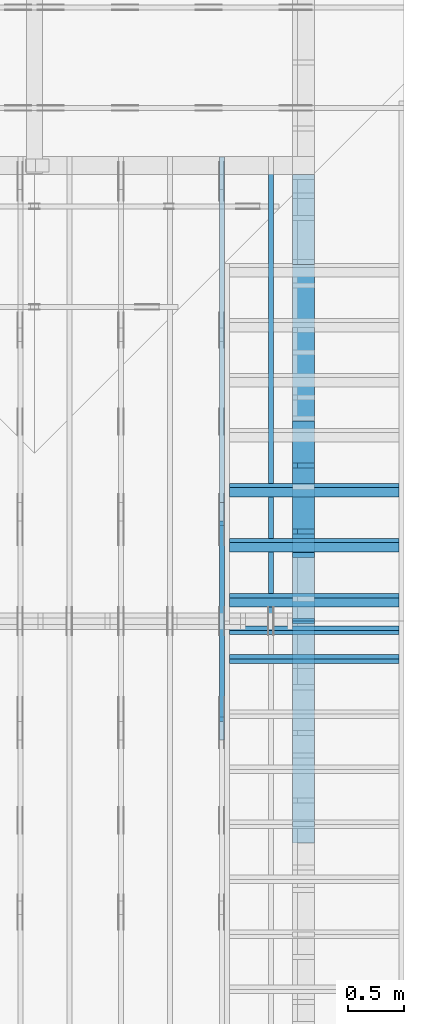
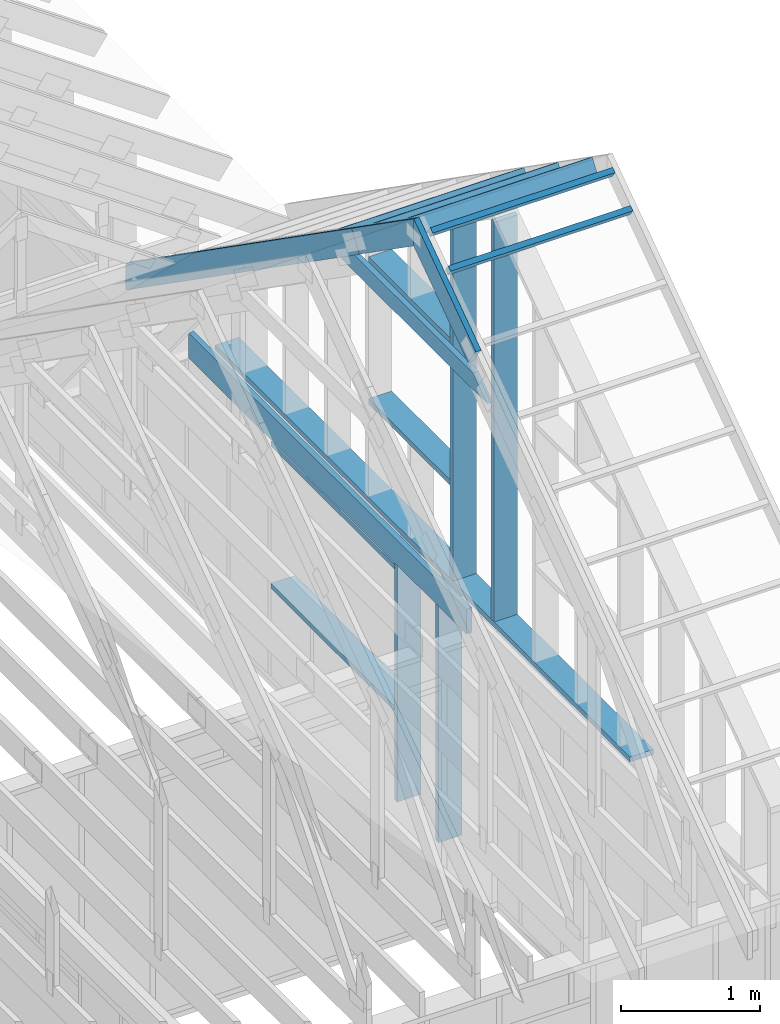
# One storey, part 27 of 70: 19 members, 6 elements without a shape of their own.
"""IFC2X3 building model written with IfcOpenShell, lengths in millimetres."""

import ifcopenshell
import ifcopenshell.guid

model = None  # the IFC model being written
_history = None  # IfcOwnerHistory: only IFC2X3 demands one
_inside = {}  # id of a spatial element -> (the spatial element, [elements in it])
_under = {}  # id of a project, library or spatial element -> (it, [spatial elements below it])
_declared = {}  # id of a project -> (the project, [libraries it declares])
_typed = {}  # id of a type object -> (the type object, [elements of that type])
_made_of = {}  # id of a material, layer set ... -> (it, [elements and type objects made of it])


def new_model(schema):
    """Start an empty IFC model of exactly this schema.

    Asked for "IFC4X3", IfcOpenShell would pick the latest addendum, in which some entities
    have other attributes; the version numbers below select the first issue.
    IFC2X3 requires an IfcOwnerHistory on every rooted entity: one is made here for all.
    """
    global model, _history
    if schema == "IFC4X3":
        model = ifcopenshell.file(schema_version=(4, 3, 0, 0))
    else:
        model = ifcopenshell.file(schema=schema)
    _inside.clear()
    _under.clear()
    _declared.clear()
    _typed.clear()
    _made_of.clear()
    _history = None
    if model.schema == "IFC2X3":
        org = make("IfcOrganization", Name="unknown")
        user = make(
            "IfcPersonAndOrganization",
            ThePerson=make("IfcPerson", FamilyName="unknown"),
            TheOrganization=org,
        )
        app = make(
            "IfcApplication",
            ApplicationDeveloper=org,
            Version="unknown",
            ApplicationFullName="unknown",
            ApplicationIdentifier="unknown",
        )
        _history = make(
            "IfcOwnerHistory",
            OwningUser=user,
            OwningApplication=app,
            ChangeAction="ADDED",
            CreationDate=0,
        )
    return model


def make(cls, **values):
    """One entity of the class cls with the attributes given. An attribute that is None is left unset."""
    return model.create_entity(
        cls, **{name: value for name, value in values.items() if value is not None}
    )


def rooted(cls, **values):
    """An entity with a GlobalId (a new one), such as an element, a storey or a relation."""
    return make(cls, GlobalId=ifcopenshell.guid.new(), OwnerHistory=_history, **values)


def si_unit(unit_type, name, prefix=None):
    """IfcSIUnit, for example si_unit("LENGTHUNIT", "METRE", prefix="MILLI")."""
    return make("IfcSIUnit", UnitType=unit_type, Prefix=prefix, Name=name)


def assignment(units):
    """IfcUnitAssignment: the units of a project."""
    return None if units is None else make("IfcUnitAssignment", Units=units)


def point(xyz):
    """IfcCartesianPoint."""
    return None if xyz is None else make("IfcCartesianPoint", Coordinates=xyz)


def direction(xyz):
    """IfcDirection."""
    return None if xyz is None else make("IfcDirection", DirectionRatios=xyz)


def frame(location, z_axis=None, x_axis=None):
    """IfcAxis2Placement3D, a coordinate frame: its origin and axes. An axis left out is left unset."""
    return make(
        "IfcAxis2Placement3D",
        Location=point(location),
        Axis=direction(z_axis),
        RefDirection=direction(x_axis),
    )


def frame_2d(location, x_axis=None):
    """IfcAxis2Placement2D, a coordinate frame in the plane: its origin and x axis."""
    return make(
        "IfcAxis2Placement2D", Location=point(location), RefDirection=direction(x_axis)
    )


def origin():
    """The frame at (0, 0, 0) with its axes left unset."""
    return frame((0.0, 0.0, 0.0))


def origin_with_axes():
    """The frame at (0, 0, 0) with the z axis (0, 0, 1) and the x axis (1, 0, 0) written out."""
    return frame((0.0, 0.0, 0.0), z_axis=(0.0, 0.0, 1.0), x_axis=(1.0, 0.0, 0.0))


def origin_2d():
    """The frame at (0, 0) in the plane with its x axis left unset."""
    return frame_2d((0.0, 0.0))


def place(relative_to, where):
    """IfcLocalPlacement: puts the frame where relative to a parent placement (None: the world)."""
    return make(
        "IfcLocalPlacement", PlacementRelTo=relative_to, RelativePlacement=where
    )


def context(
    kind, dimensions, precision=None, world=None, true_north=None, identifier=None
):
    """IfcGeometricRepresentationContext, for example the 3D "Model" context."""
    return make(
        "IfcGeometricRepresentationContext",
        ContextIdentifier=identifier,
        ContextType=kind,
        CoordinateSpaceDimension=dimensions,
        Precision=precision,
        WorldCoordinateSystem=world,
        TrueNorth=true_north,
    )


def project(units=None, contexts=None):
    """IfcProject with its units and contexts."""
    return rooted(
        "IfcProject",
        Name="project",
        RepresentationContexts=contexts,
        UnitsInContext=assignment(units),
    )


def spatial(cls, under=None, at=None, **own):
    """A site, building, storey or space (cls), placed at a placement, below another one or the project."""
    s = rooted(cls, ObjectPlacement=at, **own)
    if under is not None:
        _under.setdefault(under.id(), (under, []))[1].append(s)
    return s


def faces_of(points, faces, orient=None, outer=None):
    """IfcFace entities. A face is a list of loops; a loop is a list of indices into points, from 0.

    orient and outer hold one flag for each loop. By default every Orientation is true, the
    first loop of a face is its IfcFaceOuterBound and the others are IfcFaceBound.
    """
    made = []
    for i, loops in enumerate(faces):
        bounds = []
        for j, loop in enumerate(loops):
            is_outer = j == 0 if outer is None else outer[i][j]
            bounds.append(
                make(
                    "IfcFaceOuterBound" if is_outer else "IfcFaceBound",
                    Bound=make("IfcPolyLoop", Polygon=[points[k] for k in loop]),
                    Orientation=True if orient is None else orient[i][j],
                )
            )
        made.append(make("IfcFace", Bounds=bounds))
    return made


def faceted_brep(points, faces, orient=None, outer=None, voids=None):
    """IfcFacetedBrep: a solid bounded by flat faces; with voids (closed shells), ...WithVoids."""
    shared = [point(p) for p in points]
    hull = make("IfcClosedShell", CfsFaces=faces_of(shared, faces, orient, outer))
    if voids is None:
        return make("IfcFacetedBrep", Outer=hull)
    return make(
        "IfcFacetedBrepWithVoids",
        Outer=hull,
        Voids=[
            make(cls, CfsFaces=faces_of(shared, fs, o, b)) for cls, fs, o, b in voids
        ],
    )


def shape(context_of_items, identifier, shape_type, items):
    """IfcShapeRepresentation: the items that make up one representation, for example the "Body"."""
    return make(
        "IfcShapeRepresentation",
        ContextOfItems=context_of_items,
        RepresentationIdentifier=identifier,
        RepresentationType=shape_type,
        Items=items,
    )


def made_of(thing, what):
    """Note that an element or type object is made of a material, layer set ...; save() writes the relation."""
    if what is not None:
        _made_of.setdefault(what.id(), (what, []))[1].append(thing)
    return thing


def element(
    cls,
    number,
    at=None,
    inside=None,
    cuts=None,
    type_object=None,
    material=None,
    context=None,
    identifier="Body",
    shape_type=None,
    held_by="IfcProductDefinitionShape",
    body=None,
    shapes=None,
    **own,
):
    """One element of the class cls, such as IfcWall. Its Tag is "e" and its number.

    at: its placement. inside: the storey or other place that contains it. cuts: it is an
    opening in that element (IfcRelVoidsElement). A single representation is given by context,
    identifier, shape_type and body (its items); several are given by shapes. held_by: the class
    of the entity that holds the representations. save() writes the other relations.
    """
    e = rooted(cls, Tag="e%d" % number, ObjectPlacement=at, **own)
    if body is not None:
        shapes = [shape(context, identifier, shape_type, body)]
    if shapes is not None:
        e.Representation = make(held_by, Representations=shapes)
    if inside is not None:
        _inside.setdefault(inside.id(), (inside, []))[1].append(e)
    if cuts is not None:
        rooted(
            "IfcRelVoidsElement", RelatingBuildingElement=cuts, RelatedOpeningElement=e
        )
    if type_object is not None:
        _typed.setdefault(type_object.id(), (type_object, []))[1].append(e)
    return made_of(e, material)


def aggregate(whole, parts):
    """IfcRelAggregates: a whole, such as a stair, and the parts it consists of."""
    return rooted("IfcRelAggregates", RelatingObject=whole, RelatedObjects=parts)


def save(model, path):
    """Write the relations noted so far, then the file.

    IfcRelAggregates (storeys below a building ...), IfcRelContainedInSpatialStructure (elements
    in a storey), IfcRelDefinesByType, IfcRelAssociatesMaterial and IfcRelDeclares: one each for
    every whole, place, type object, material and project.
    """
    for whole, parts in _under.values():
        aggregate(whole, parts)
    for where, things in _inside.values():
        rooted(
            "IfcRelContainedInSpatialStructure",
            RelatedElements=things,
            RelatingStructure=where,
        )
    for kind, things in _typed.values():
        rooted("IfcRelDefinesByType", RelatedObjects=things, RelatingType=kind)
    for what, things in _made_of.values():
        rooted("IfcRelAssociatesMaterial", RelatedObjects=things, RelatingMaterial=what)
    for by, libraries in _declared.values():
        rooted("IfcRelDeclares", RelatingContext=by, RelatedDefinitions=libraries)
    model.write(path)


model = new_model("IFC2X3")

# Units and contexts
model_context = context("Model", 3, precision=1e-05, world=origin())
plan_context = context("Plan", 2, precision=1e-05, world=origin_2d())
ifc_project = project(units=[si_unit("LENGTHUNIT", "METRE", prefix="MILLI"), si_unit("AREAUNIT", "SQUARE_METRE"), si_unit("VOLUMEUNIT", "CUBIC_METRE"), si_unit("SOLIDANGLEUNIT", "STERADIAN"), si_unit("PLANEANGLEUNIT", "RADIAN"), si_unit("MASSUNIT", "GRAM"), si_unit("TIMEUNIT", "SECOND"), si_unit("THERMODYNAMICTEMPERATUREUNIT", "DEGREE_CELSIUS"), si_unit("LUMINOUSINTENSITYUNIT", "LUMEN")], contexts=[model_context, plan_context])

# Site, building, storey
site_placement = place(None, origin_with_axes())
site = spatial("IfcSite", under=ifc_project, at=site_placement, CompositionType="ELEMENT")
building_placement = place(site_placement, origin_with_axes())
building = spatial("IfcBuilding", under=site, at=building_placement, Name="Layout 1", CompositionType="ELEMENT")
storey_placement = place(building_placement, origin_with_axes())
storey = spatial("IfcBuildingStorey", under=building, at=storey_placement, Name="Storey 1", CompositionType="ELEMENT", Elevation=0.0)

# Assembly, members
assembly_1_placement = place(storey_placement, frame((12000.0, 0.0, -2470.0), z_axis=(1.0, -6.123031769111886e-17, 6.123031769111886e-17), x_axis=(6.123031769111886e-17, 1.0, 0.0)))
assembly_1 = element("IfcElementAssembly", 1, at=assembly_1_placement, inside=storey, Name="VE5", AssemblyPlace="FACTORY", PredefinedType="NOTDEFINED")
member_1_placement = place(assembly_1_placement, frame((4777.5000000018335, 2425.0, -195.00000000000003), z_axis=(0.0, 0.0, 1.0), x_axis=(-1.836909530733566e-16, -1.0, 0.0)))
member_1 = element("IfcMember", 2, at=member_1_placement, Name="S11", context=model_context, shape_type="Brep", body=[
    faceted_brep([(0.0, 45.0, 45.00000000000003), (195.00000000186265, 45.0, 45.00000000000005), (195.00000000186265, 0.0, 45.00000000000005), (0.0, 0.0, 45.00000000000003), (195.00000000186265, -2.1311460639909362e-46, 2.842170943040401e-14), (195.00000000186265, -3.3742366240998114e-31, 45.00000000000003), (195.00000000186265, 45.0, 45.00000000000003), (195.00000000186265, 45.0, 2.842170943040401e-14), (2.7553642961003504e-15, -3.3742366240998114e-31, 45.00000000000003), (1.193991194976818e-14, -1.4621692037765842e-30, 195.00000000000003), (1.7450640541968876e-14, 45.0, 195.00000000000003), (8.266092888301048e-15, 45.0, 45.00000000000003), (2335.0, -4.2891837542628763e-13, 2.842170943040403e-14), (2335.0, -4.1697846347651946e-13, 195.00000000000003), (2.1932538056648764e-30, 1.193991194976818e-14, 195.00000000000003), (5.061354936149717e-31, 2.7553642961003504e-15, 45.00000000000003), (195.00000000186265, -3.306437155354634e-14, 45.00000000000003), (195.00000000186265, -3.5819735849646686e-14, 2.842170943040401e-14), (-1.6871183120499057e-31, 45.0, 45.00000000000003), (-7.310846018882921e-31, 44.999999999999986, 195.00000000000003), (2335.0, 44.999999999999844, 195.00000000000003), (2335.0, 44.99999999999986, 2.8421709430403998e-14), (195.00000000186265, 44.999999999999986, 2.842170943040401e-14), (195.00000000186265, 44.999999999999986, 45.00000000000003), (2335.0, 45.0, 0.0), (2335.0, 45.0, 195.00000000000003), (2335.0, 0.0, 195.00000000000003), (2335.0, 0.0, 0.0), (2335.0, 45.0, 195.00000000000003), (0.0, 45.0, 195.00000000000003), (0.0, 0.0, 195.00000000000003), (2335.0, 0.0, 195.00000000000003), (195.00000000186265, 45.0, 5.2301533330168465e-14), (2335.0, 45.0, 3.143672930479291e-13), (2335.0, 0.0, 3.143672930479291e-13), (195.00000000186265, 0.0, 5.2301533330168465e-14)], [[[0, 1, 2, 3]], [[4, 5, 6, 7]], [[8, 9, 10, 11]], [[12, 13, 14, 15, 16, 17]], [[18, 19, 20, 21, 22, 23]], [[24, 25, 26, 27]], [[28, 29, 30, 31]], [[32, 33, 34, 35]]]),
])
member_2_placement = place(assembly_1_placement, frame((5367.500000003667, 2425.0, -195.00000000000003), z_axis=(0.0, 0.0, 1.0), x_axis=(-1.836909530733566e-16, -1.0, 0.0)))
member_2 = element("IfcMember", 3, at=member_2_placement, Name="S11", context=model_context, shape_type="Brep", body=[
    faceted_brep([(0.0, 45.0, 45.00000000000003), (195.00000000186265, 45.0, 45.00000000000005), (195.00000000186265, 0.0, 45.00000000000005), (0.0, 0.0, 45.00000000000003), (195.00000000186265, 9.094947017729282e-13, 2.842170943040401e-14), (195.00000000186265, 9.094947017729282e-13, 45.00000000000003), (195.00000000186265, 45.00000000000091, 45.00000000000003), (195.00000000186265, 45.00000000000091, 2.842170943040401e-14), (2.7553642961003504e-15, -3.3742366240998114e-31, 45.00000000000003), (1.193991194976818e-14, -1.4621692037765842e-30, 195.00000000000003), (1.7450640541968876e-14, 45.0, 195.00000000000003), (8.266092888301048e-15, 45.0, 45.00000000000003), (2335.0, -4.2891837542628763e-13, 2.842170943040403e-14), (2335.0, -4.1697846347651946e-13, 195.00000000000003), (2.1932538056648764e-30, 1.193991194976818e-14, 195.00000000000003), (5.061354936149717e-31, 2.7553642961003504e-15, 45.00000000000003), (195.00000000186265, -3.306437155354634e-14, 45.00000000000003), (195.00000000186265, -3.5819735849646686e-14, 2.842170943040401e-14), (-1.6871183120499057e-31, 45.00000000000091, 45.00000000000003), (-7.310846018882921e-31, 45.000000000000895, 195.00000000000003), (2335.0, 45.00000000000075, 195.00000000000003), (2335.0, 45.00000000000077, 2.8421709430404e-14), (195.00000000186265, 45.000000000000895, 2.842170943040401e-14), (195.00000000186265, 45.000000000000895, 45.00000000000003), (2335.0, 45.00000000001455, 0.0), (2335.0, 45.00000000001455, 195.00000000000003), (2335.0, 1.4551915228366852e-11, 195.00000000000003), (2335.0, 1.4551915228366852e-11, 0.0), (2335.0, 45.00000000001455, 195.00000000000003), (0.0, 45.00000000001455, 195.00000000000003), (0.0, 0.0, 195.00000000000003), (2335.0, 0.0, 195.00000000000003), (195.00000000186265, 45.00000000000091, 5.2301533330168465e-14), (2335.0, 45.00000000000091, 3.143672930479291e-13), (2335.0, 1.4551915228366852e-11, 3.143672930479291e-13), (195.00000000186265, 1.4551915228366852e-11, 5.2301533330168465e-14)], [[[0, 1, 2, 3]], [[4, 5, 6, 7]], [[8, 9, 10, 11]], [[12, 13, 14, 15, 16, 17]], [[18, 19, 20, 21, 22, 23]], [[24, 25, 26, 27]], [[28, 29, 30, 31]], [[32, 33, 34, 35]]]),
])
member_3_placement = place(assembly_1_placement, frame((7187.500000001819, 2154.9999999987776, -195.0), z_axis=(0.0, 0.0, 1.0), x_axis=(-1.0, 1.2246063538223773e-16, 0.0)))
member_3 = element("IfcMember", 4, at=member_3_placement, Name="S17", context=model_context, shape_type="Brep", body=[
    faceted_brep([(1774.9999999999854, 45.00000000001501, 195.0), (0.0, 45.00000000001501, 195.0), (0.0, 0.0, 195.0), (1774.9999999999854, 0.0, 195.0), (0.0, 45.00000000001501, 0.0), (1774.9999999999854, 45.00000000001501, 2.1736762780347017e-13), (1774.9999999999854, 0.0, 2.1736762780347017e-13), (0.0, 0.0, 0.0), (0.0, 0.0, 0.0), (1.1939911949768178e-14, -1.462169203776584e-30, 195.0), (1.745064054197066e-14, 45.00000000001455, 195.0), (5.51072859220248e-15, 45.00000000001455, -3.3742366241009005e-31), (1774.9999999999854, -3.2605144170520527e-13, 4.7808558123229943e-29), (1774.9999999999854, -3.141115297554371e-13, 195.0), (2.193253805664876e-30, 1.1939911949768178e-14, 195.0), (0.0, 0.0, 0.0), (1774.9999999999854, 45.00000000001501, 0.0), (1774.9999999999854, 45.00000000001501, 195.0), (1774.9999999999854, 4.547473508864641e-13, 195.0), (1774.9999999999854, 4.547473508864641e-13, 0.0), (0.0, 45.00000000001455, 0.0), (1.5777218104420236e-30, 45.00000000001454, 195.0), (1774.9999999999854, 45.00000000001482, 195.0), (1774.9999999999854, 45.000000000014836, -1.064962222048366e-29)], [[[0, 1, 2, 3]], [[4, 5, 6, 7]], [[8, 9, 10, 11]], [[12, 13, 14, 15]], [[16, 17, 18, 19]], [[20, 21, 22, 23]]]),
])
member_4_placement = place(assembly_1_placement, frame((5412.5000000018335, 863.1713847472129, -195.0), z_axis=(0.0, 0.0, 1.0), x_axis=(1.0, 0.0, 0.0)))
member_4 = element("IfcMember", 5, at=member_4_placement, Name="S17", context=model_context, shape_type="Brep", body=[
    faceted_brep([(1774.9999999999854, 45.0, 195.0), (0.0, 45.0, 195.0), (0.0, 0.0, 195.0), (1774.9999999999854, 0.0, 195.0), (0.0, 45.0, 0.0), (1774.9999999999854, 45.0, 2.1736762780347017e-13), (1774.9999999999854, 0.0, 2.1736762780347017e-13), (0.0, 0.0, 0.0), (0.0, 0.0, 0.0), (1.1939911949768178e-14, -1.462169203776584e-30, 195.0), (1.7450640541968876e-14, 45.0, 195.0), (5.510728592200698e-15, 45.0, -3.3742366240998092e-31), (1774.9999999999854, -3.2605144170520527e-13, 1.9964233359257042e-29), (1774.9999999999854, -3.141115297554371e-13, 195.0), (2.193253805664876e-30, 1.1939911949768178e-14, 195.0), (0.0, 0.0, 0.0), (1774.9999999999854, 45.0, 0.0), (1774.9999999999854, 45.0, 195.0), (1774.9999999999854, 0.0, 195.0), (1774.9999999999854, 0.0, 0.0), (0.0, 45.0, 0.0), (-7.31084601888292e-31, 44.999999999999986, 195.0), (1774.9999999999854, 44.99999999999988, 195.0), (1774.9999999999854, 44.99999999999989, -6.7053176943786e-30)], [[[0, 1, 2, 3]], [[4, 5, 6, 7]], [[8, 9, 10, 11]], [[12, 13, 14, 15]], [[16, 17, 18, 19]], [[20, 21, 22, 23]]]),
])
aggregate(assembly_1, [member_1, member_2, member_3, member_4])

# Assembly, member
assembly_2_placement = place(storey_placement, frame((11588.750000000146, 8000.0, 1.3776821480501744e-15), z_axis=(-1.0, 1.836909530733566e-16, 6.123031769111886e-17), x_axis=(-1.836909530733566e-16, -1.0, 0.0)))
assembly_2 = element("IfcElementAssembly", 6, at=assembly_2_placement, inside=storey, Name="MB1", AssemblyPlace="FACTORY", PredefinedType="TRUSS")
member_5_placement = place(assembly_2_placement, frame((4000.0000000000005, 219.99999999999997, -45.0), z_axis=(0.0, 0.0, 1.0), x_axis=(-1.0, 1.2246063538223773e-16, 0.0)))
member_5 = element("IfcMember", 7, at=member_5_placement, Name="B3", context=model_context, shape_type="Brep", body=[
    faceted_brep([(4000.0000000000005, 220.00000000000045, 45.0), (0.0, 220.00000000000045, 45.0), (0.0, 0.0, 45.0), (4000.0000000000005, 0.0, 45.0), (0.0, 220.00000000000045, 0.0), (4000.0000000000005, 220.00000000000045, 4.89842541528951e-13), (4000.0000000000005, 0.0, 4.89842541528951e-13), (0.0, 0.0, 0.0), (0.0, 0.0, 0.0), (2.755364296100349e-15, -3.3742366240998092e-31, 45.0), (2.969670408019265e-14, 220.0, 45.0), (2.69413397840923e-14, 220.0, -1.6496267940043512e-30), (4000.0000000000005, -7.347638122934265e-13, 7.283414641863702e-29), (4000.0000000000005, -7.320084479973261e-13, 45.0), (5.061354936149714e-31, 2.755364296100349e-15, 45.0), (0.0, 0.0, 0.0), (4000.0000000000005, 220.00000000000045, 0.0), (4000.0000000000005, 220.00000000000045, 45.0), (4000.0000000000005, 4.547473508864641e-13, 45.0), (4000.0000000000005, 4.547473508864641e-13, 0.0), (0.0, 220.0, 0.0), (0.0, 220.0, 45.0), (4000.0000000000005, 220.00000000000065, 45.0), (4000.0000000000005, 220.00000000000065, 1.1044052673094165e-29)], [[[0, 1, 2, 3]], [[4, 5, 6, 7]], [[8, 9, 10, 11]], [[12, 13, 14, 15]], [[16, 17, 18, 19]], [[20, 21, 22, 23]]]),
])
aggregate(assembly_2, [member_5])

# Assembly, members
assembly_3_placement = place(storey_placement, frame((11150.0, 8000.0, -9.081170196248781e-13), z_axis=(-1.0, 1.836909530733566e-16, 6.123031769111886e-17), x_axis=(-1.836909530733566e-16, -1.0, 0.0)))
assembly_3 = element("IfcElementAssembly", 8, at=assembly_3_placement, inside=storey, Name="T3", AssemblyPlace="FACTORY", PredefinedType="TRUSS")
member_6_placement = place(assembly_3_placement, frame((-145.0000000000008, 660.4188621509819, -45.0), z_axis=(0.0, 0.0, 1.0), x_axis=(0.8191520442889915, 0.5735764363510465, 0.0)))
member_6 = element("IfcMember", 9, at=member_6_placement, Name="T10", context=model_context, shape_type="Brep", body=[
    faceted_brep([(4105.08693981286, 195.00000000242483, 45.0), (136.5404699510177, 195.00000000242483, 45.0), (0.0, 0.0, 45.0), (4105.08693981249, 0.0, 45.0), (136.5404699510177, 195.00000000242483, 1.6720832705590965e-14), (4105.08693981286, 195.00000000242483, 5.027115549488087e-13), (4105.08693981249, 0.0, 5.027115549487634e-13), (0.0, 0.0, 0.0), (-1.1640850691051581e-14, 8.151011405048023e-15, 8.701351488741532e-31), (-9.383788395140082e-15, 6.570599371241877e-15, 45.0), (136.54046995101766, 195.00000000017752, 45.0), (136.54046995101766, 195.00000000017752, 4.814439674979212e-30), (4105.08693981249, 2.4530373342863473e-09, 2.683789629641233e-29), (4105.08693981249, 2.4530400896506434e-09, 45.0), (-1.646496550984743e-27, 2.755364296100349e-15, 45.0), (0.0, 0.0, 0.0), (4105.08693981249, 195.00000000242483, -2.2668706972430995e-26), (4105.08693981249, 195.00000000242483, 45.0), (4105.08693981249, 2.4534756448701955e-09, 45.0), (4105.08693981249, 2.4534756448701955e-09, 0.0), (136.5404699510177, 195.00000000017747, 0.0), (136.5404699510177, 195.00000000017747, 45.0), (4105.08693981286, 195.00000000242514, 45.0), (4105.08693981286, 195.00000000242514, 1.8932661725304283e-29)], [[[0, 1, 2, 3]], [[4, 5, 6, 7]], [[8, 9, 10, 11]], [[12, 13, 14, 15]], [[16, 17, 18, 19]], [[20, 21, 22, 23]]]),
])
member_7_placement = place(assembly_3_placement, frame((5060.798502586593, 2964.999999998785, -45.0), z_axis=(0.0, 0.0, 1.0), x_axis=(-1.0, 1.2246063538223773e-16, 0.0)))
member_7 = element("IfcMember", 10, at=member_7_placement, Name="C1", context=model_context, shape_type="Brep", body=[
    faceted_brep([(2121.597005175296, 145.00000000000728, 45.0), (0.0, 145.00000000000728, 45.0), (207.08146097743884, 0.0, 45.0), (1914.5155441979737, 0.0, 45.0), (0.0, 145.00000000000728, 0.0), (2121.597005175296, 145.00000000000728, 2.5981211727881944e-13), (1914.5155441979737, 0.0, 2.3445278999165447e-13), (207.08146097743884, 0.0, 2.5359327287179227e-14), (207.08146097743878, -7.105427357601002e-14, 3.1554436208840472e-30), (207.08146097743878, -7.105427357601002e-14, 45.0), (1.4210854715202004e-14, 145.00000000000728, 45.0), (1.4210854715202004e-14, 145.00000000000728, 0.0), (1914.5155441979737, 7.26803319922997e-12, 4.8521444511629875e-31), (1914.5155441979737, 7.27078856352607e-12, 45.0), (207.08146097743884, 1.898228698049977e-15, 45.0), (207.08146097743884, -8.571355980503717e-16, 5.248268497299439e-32), (2121.597005175296, 145.00000000000728, 0.0), (2121.597005175296, 145.00000000000728, 45.0), (1914.515544197974, 7.389644451905042e-12, 45.0), (1914.515544197974, 7.389644451905042e-12, 1.262177448353619e-29), (0.0, 145.00000000000728, 0.0), (-1.6871183120499046e-31, 145.00000000000728, 45.0), (2121.597005175296, 145.00000000000713, 45.0), (2121.597005175296, 145.00000000000713, -7.888609052210118e-30)], [[[0, 1, 2, 3]], [[4, 5, 6, 7]], [[8, 9, 10, 11]], [[12, 13, 14, 15]], [[16, 17, 18, 19]], [[20, 21, 22, 23]]]),
])
member_8_placement = place(assembly_3_placement, frame((3888.1525949105694, 3641.0955042035366, -45.00000000000001), z_axis=(0.0, 0.0, 1.0), x_axis=(0.8191520442889916, -0.5735764363510465, 0.0)))
member_8 = element("IfcMember", 11, at=member_8_placement, Name="T18", context=model_context, shape_type="Brep", body=[
    faceted_brep([(1091.5642005560503, 194.99999999996362, 45.0), (0.0, 194.99999999996362, 45.0), (136.54046995208614, 0.0, 45.0), (1091.5642005561149, 0.0, 45.0), (0.0, 194.99999999996362, 0.0), (1091.5642005560503, 194.99999999996362, 1.336736455605983e-13), (1091.5642005561149, 0.0, 1.336736455606062e-13), (136.54046995208614, 0.0, 1.6720832705721806e-14), (136.54046995208614, -2.842170943040401e-14, 3.0619884913871384e-31), (136.54046995208614, -2.842170943040401e-14, 45.0), (1.4210854715202004e-14, 195.00000000170263, 45.0), (1.4210854715202004e-14, 195.00000000170263, -5.932810329456638e-31), (1091.5642005561149, 2.0525182992035534e-09, 1.2934457505131873e-29), (1091.5642005561149, 2.0525210545678495e-09, 45.0), (136.54046995208614, -2.3668346958569874e-14, 45.0), (136.54046995208614, -2.6423711254670222e-14, 1.6179322347011683e-30), (1091.5642005561149, 194.99999999996362, 3.950615413346827e-27), (1091.5642005561149, 194.99999999996362, 45.0), (1091.5642005561149, 2.052729541901499e-09, 45.0), (1091.5642005561149, 2.052729541901499e-09, 0.0), (0.0, 195.00000000170257, 0.0), (0.0, 195.00000000170257, 45.0), (1091.5642005560503, 194.9999999999637, 45.0), (1091.5642005560503, 194.9999999999637, 6.310887241768095e-30)], [[[0, 1, 2, 3]], [[4, 5, 6, 7]], [[8, 9, 10, 11]], [[12, 13, 14, 15]], [[16, 17, 18, 19]], [[20, 21, 22, 23]]]),
])
member_9_placement = place(assembly_3_placement, frame((3217.690358731264, 3015.0000000002183, -45.00000000000001), z_axis=(0.0, 0.0, 1.0), x_axis=(0.8191520442889918, 0.5735764363510462, 0.0)))
member_9 = element("IfcMember", 12, at=member_9_placement, Name="T18", context=model_context, shape_type="Brep", body=[
    faceted_brep([(1091.564200553914, 194.99999999865213, 45.0), (0.0, 194.99999999865213, 45.0), (1.6370904631912708e-10, 7.557900971733034e-10, 45.0), (955.0237306039635, 7.557900971733034e-10, 45.0), (0.0, 194.99999999865213, 0.0), (1091.564200553914, 194.99999999865213, 1.3367364556033665e-13), (955.0237306039635, 7.557900971733034e-10, 1.169528128548764e-13), (1.6370904631912708e-10, 7.557900971733034e-10, 2.004791383006049e-26), (1.6370904631912732e-10, 7.557900971733033e-10, -1.4349296274686127e-41), (1.6371180168342342e-10, 7.557900971733033e-10, 45.0), (6.660321774678196e-14, 194.99999999996407, 45.0), (6.384785345068161e-14, 194.99999999996407, -3.909424350681179e-30), (955.0237306039635, -1.5956987698560245e-13, 9.770514261762543e-30), (955.0237306039635, -1.568145126895021e-13, 45.0), (1.6370904631912708e-10, 7.557928525375995e-10, 45.0), (1.6370904631912708e-10, 7.557900971733034e-10, 0.0), (1091.564200553914, 194.99999999865213, 0.0), (1091.564200553914, 194.99999999865213, 45.0), (955.0237306039635, -5.684341886080802e-14, 45.0), (955.0237306039635, -5.684341886080802e-14, -6.310887241768095e-30), (0.0, 194.99999999996407, 0.0), (0.0, 194.99999999996407, 45.0), (1091.564200553914, 194.99999999865202, 45.0), (1091.564200553914, 194.99999999865202, -6.310887241768095e-30)], [[[0, 1, 2, 3]], [[4, 5, 6, 7]], [[8, 9, 10, 11]], [[12, 13, 14, 15]], [[16, 17, 18, 19]], [[20, 21, 22, 23]]]),
])
aggregate(assembly_3, [member_6, member_7, member_8, member_9])

assembly_4_placement = place(storey_placement, frame((11805.0, 8000.000000000002, 1.1939911949768178e-14), z_axis=(-1.0, 1.836909530733566e-16, 6.123031769111886e-17), x_axis=(-1.836909530733566e-16, -1.0, 0.0)))
assembly_4 = element("IfcElementAssembly", 13, at=assembly_4_placement, inside=storey, Name="VE9", AssemblyPlace="FACTORY", PredefinedType="NOTDEFINED")
member_10_placement = place(assembly_4_placement, frame((5980.000000000001, 45.0, -195.0), z_axis=(0.0, 0.0, 1.0), x_axis=(-1.0, 1.2246063538223773e-16, 0.0)))
member_10 = element("IfcMember", 14, at=member_10_placement, Name="P2", context=model_context, shape_type="Brep", body=[
    faceted_brep([(5970.000000000363, 45.00000000000073, 195.0), (0.0, 45.00000000000073, 195.0), (0.0, 0.0, 195.0), (5970.000000000363, 0.0, 195.0), (0.0, 45.00000000000073, 0.0), (5970.000000000363, 45.00000000000073, 7.310899932320037e-13), (5970.000000000363, 0.0, 7.310899932320037e-13), (0.0, 0.0, 0.0), (0.0, 0.0, 0.0), (1.1939911949768178e-14, -1.462169203776584e-30, 195.0), (1.7450640541968876e-14, 45.0, 195.0), (5.510728592200698e-15, 45.0, -3.3742366240998092e-31), (5970.000000000363, -1.0966349898480055e-12, 1.1195926898660917e-28), (5970.000000000363, -1.0846950778982373e-12, 195.0), (2.193253805664876e-30, 1.1939911949768178e-14, 195.0), (0.0, 0.0, 0.0), (5970.000000000363, 45.00000000000073, 0.0), (5970.000000000363, 45.00000000000073, 195.0), (5970.000000000363, 7.318590178329032e-13, 195.0), (5970.000000000363, 7.318590178329032e-13, 0.0), (0.0, 45.0, 0.0), (1.5777218104420236e-30, 44.999999999999986, 195.0), (5970.000000000363, 45.000000000000945, 195.0), (5970.000000000363, 45.00000000000096, 1.3805065841367707e-29)], [[[0, 1, 2, 3]], [[4, 5, 6, 7]], [[8, 9, 10, 11]], [[12, 13, 14, 15]], [[16, 17, 18, 19]], [[20, 21, 22, 23]]]),
])
member_11_placement = place(assembly_4_placement, frame((3977.500000001819, 3568.8829809762537, -195.0), z_axis=(0.0, 0.0, 1.0), x_axis=(-1.836909530733566e-16, -1.0, 0.0)))
member_11 = element("IfcMember", 15, at=member_11_placement, Name="S3", context=model_context, shape_type="Brep", body=[
    faceted_brep([(3523.8829809762537, 45.000000000000455, 195.0), (15.754669611007557, 45.000000000000455, 195.0), (0.0, 22.49999999818101, 195.0), (15.75466961030179, 0.0, 195.0), (3523.8829809762537, 0.0, 195.0), (15.754669611007557, 45.000000000000455, 1.9293268508012175e-15), (3523.8829809762537, 45.000000000000455, 4.3153694886300597e-13), (3523.8829809762537, 0.0, 4.3153694886300597e-13), (15.75466961030179, 0.0, 1.9293268507147887e-15), (0.0, 22.49999999818101, 0.0), (1.7763568394002505e-15, 22.499999998181018, -2.1895288505075267e-47), (1.2434497875801753e-14, 22.49999999818101, 195.0), (15.754669611007566, 45.00000000001456, 195.0), (15.754669611007555, 45.000000000014566, 3.944304526105059e-31), (15.754669610301788, 0.0, 9.860761315262648e-32), (15.754669610301796, 7.105427357601002e-15, 195.0), (1.4210854715202004e-14, 22.49999999818102, 195.0), (3.552713678800501e-15, 22.499999998181014, -1.9721522630525295e-31), (3523.8829809762537, -6.493476502695498e-13, 6.760408768195898e-29), (3523.8829809762537, -6.374077383197816e-13, 195.0), (15.75466961030179, 7.003694698655098e-15, 195.0), (15.75466961030179, -4.9362172511130804e-15, 3.022461504780354e-31), (3523.8829809762537, 45.000000000000455, 0.0), (3523.8829809762537, 45.000000000000455, 195.0), (3523.8829809762537, 4.547473508864641e-13, 195.0), (3523.8829809762537, 4.547473508864641e-13, 0.0), (15.754669611007557, 45.00000000001455, 0.0), (15.754669611007557, 45.00000000001454, 195.0), (3523.8829809762537, 45.000000000000306, 195.0), (3523.8829809762537, 45.00000000000031, -8.67746995743113e-30)], [[[0, 1, 2, 3, 4]], [[5, 6, 7, 8, 9]], [[10, 11, 12, 13]], [[14, 15, 16, 17]], [[18, 19, 20, 21]], [[22, 23, 24, 25]], [[26, 27, 28, 29]]]),
])
member_12_placement = place(assembly_4_placement, frame((3387.5000000036525, 3171.5152030430545, -195.0), z_axis=(0.0, 0.0, 1.0), x_axis=(-1.836909530733566e-16, -1.0, 0.0)))
member_12 = element("IfcMember", 16, at=member_12_placement, Name="S6", context=model_context, shape_type="Brep", body=[
    faceted_brep([(3126.5152030430545, 44.9999999999859, 195.0), (0.0, 44.9999999999859, 195.0), (31.50933921943215, 0.0, 195.0), (3126.5152030430545, 0.0, 195.0), (0.0, 44.9999999999859, 0.0), (3126.5152030430545, 44.9999999999859, 3.8287503829687845e-13), (3126.5152030430545, 0.0, 3.8287503829687845e-13), (31.50933921943215, 0.0, 3.858653701286124e-15), (31.50933921943215, -1.7763568394002505e-15, 1.972152263052529e-31), (31.50933921943216, 5.329070518200751e-15, 195.0), (3.197442310920451e-14, 45.00000000001458, 195.0), (2.1316282072803006e-14, 45.000000000014566, -1.1832913578315177e-30), (3126.5152030430545, -5.789422057137437e-13, 6.329313994462252e-29), (3126.5152030430545, -5.670022937639756e-13, 195.0), (31.50933921943215, 1.5222831294128676e-15, 195.0), (31.50933921943215, -1.0417628820355311e-14, 6.378747222585115e-31), (3126.5152030430545, 44.9999999999859, 0.0), (3126.5152030430545, 44.9999999999859, 195.0), (3126.5152030430545, 4.547473508864641e-13, 195.0), (3126.5152030430545, 4.547473508864641e-13, 0.0), (0.0, 45.00000000001455, 0.0), (-1.0097419586828951e-28, 45.00000000001454, 195.0), (3126.5152030430545, 44.99999999998589, 195.0), (3126.5152030430545, 44.999999999985896, -3.944304526105059e-31)], [[[0, 1, 2, 3]], [[4, 5, 6, 7]], [[8, 9, 10, 11]], [[12, 13, 14, 15]], [[16, 17, 18, 19]], [[20, 21, 22, 23]]]),
])
member_13_placement = place(assembly_4_placement, frame((3387.500000001819, 2154.999999998792, -195.0), z_axis=(0.0, 0.0, 1.0), x_axis=(-1.0, 1.2246063538223773e-16, 0.0)))
member_13 = element("IfcMember", 17, at=member_13_placement, Name="S25", context=model_context, shape_type="Brep", body=[
    faceted_brep([(1175.0, 45.000000000029104, 195.0), (0.0, 45.000000000029104, 195.0), (0.0, 0.0, 195.0), (1175.0, 0.0, 195.0), (0.0, 45.000000000029104, 0.0), (1175.0, 45.000000000029104, 1.4389124657412933e-13), (1175.0, 0.0, 1.4389124657412933e-13), (0.0, 0.0, 0.0), (0.0, 0.0, 0.0), (1.1939911949768178e-14, -1.462169203776584e-30, 195.0), (1.7450640541968876e-14, 45.0, 195.0), (5.510728592200698e-15, 45.0, -3.3742366240998092e-31), (1175.0, 2.9005233138272926e-11, 6.0371451328458226e-30), (1175.0, 2.9017173050222694e-11, 195.0), (-2.947403657476399e-28, 1.1939911949768178e-14, 195.0), (0.0, 0.0, 0.0), (1175.0, 45.000000000029104, 0.0), (1175.0, 45.000000000029104, 195.0), (1175.0, 2.9103830456733704e-11, 195.0), (1175.0, 2.9103830456733704e-11, 0.0), (0.0, 45.0, 0.0), (2.0194839173657902e-28, 44.999999999999986, 195.0), (1175.0, 45.00000000002914, 195.0), (1175.0, 45.00000000002915, 2.7610131682735413e-30)], [[[0, 1, 2, 3]], [[4, 5, 6, 7]], [[8, 9, 10, 11]], [[12, 13, 14, 15]], [[16, 17, 18, 19]], [[20, 21, 22, 23]]]),
])
member_14_placement = place(assembly_4_placement, frame((2212.500000001819, 863.1713847472129, -195.0), z_axis=(0.0, 0.0, 1.0), x_axis=(1.0, 0.0, 0.0)))
member_14 = element("IfcMember", 18, at=member_14_placement, Name="S25", context=model_context, shape_type="Brep", body=[
    faceted_brep([(1175.0, 45.0, 195.0), (0.0, 45.0, 195.0), (0.0, 0.0, 195.0), (1175.0, 0.0, 195.0), (0.0, 45.0, 0.0), (1175.0, 45.0, 1.4389124657412933e-13), (1175.0, 0.0, 1.4389124657412933e-13), (0.0, 0.0, 0.0), (0.0, 0.0, 0.0), (1.1939911949768178e-14, -1.462169203776584e-30, 195.0), (1.7450640541967093e-14, 44.99999999998545, 195.0), (5.510728592198916e-15, 44.99999999998545, -3.374236624098718e-31), (1175.0, -2.15836869861194e-13, 1.3215760111057586e-29), (1175.0, -2.0389695791142581e-13, 195.0), (2.193253805664876e-30, 1.1939911949768178e-14, 195.0), (0.0, 0.0, 0.0), (1175.0, 45.0, 0.0), (1175.0, 45.0, 195.0), (1175.0, 0.0, 195.0), (1175.0, 0.0, 0.0), (0.0, 44.99999999998545, 0.0), (1.0097419586828951e-28, 44.999999999985434, 195.0), (1175.0, 44.99999999999997, 195.0), (1175.0, 44.999999999999986, -7.888609052210118e-31)], [[[0, 1, 2, 3]], [[4, 5, 6, 7]], [[8, 9, 10, 11]], [[12, 13, 14, 15]], [[16, 17, 18, 19]], [[20, 21, 22, 23]]]),
])
aggregate(assembly_4, [member_10, member_11, member_12, member_13, member_14])

assembly_5_placement = place(storey_placement, frame((12800.0, -800.0, 439.83396943223215), z_axis=(-2.4046889635939937e-17, -0.573576436351046, 0.8191520442889918), x_axis=(1.5036672491230068e-17, 0.8191520442889918, 0.573576436351046)))
assembly_5 = element("IfcElementAssembly", 19, at=assembly_5_placement, inside=storey, Name="gs2", AssemblyPlace="FACTORY", PredefinedType="TRUSS")
member_15_placement = place(assembly_5_placement, frame((5444.999999999389, 45.0, -70.0), z_axis=(0.0, 0.0, 1.0), x_axis=(6.123031769111886e-17, 1.0, 0.0)))
member_15 = element("IfcMember", 20, at=member_15_placement, Name="W5", context=model_context, shape_type="Brep", body=[
    faceted_brep([(1514.9999999999982, 44.99999999998545, 70.0), (0.0, 44.99999999998545, 70.0), (0.0, 0.0, 70.0), (1514.9999999999982, 0.0, 70.0), (0.0, 44.99999999998545, 0.0), (1514.9999999999982, 44.99999999998545, 1.8552786260408993e-13), (1514.9999999999982, 0.0, 1.8552786260408993e-13), (0.0, 0.0, 0.0), (0.0, 0.0, 0.0), (4.2861222383783204e-15, -5.248812526377481e-31, 70.0), (9.796850830579018e-15, 45.0, 70.0), (5.510728592200698e-15, 45.0, -3.3742366240998092e-31), (1514.9999999999982, -2.782917939061349e-13, 1.7039894951704017e-29), (1514.9999999999982, -2.7400567166775656e-13, 70.0), (7.8732187895662216e-31, 4.2861222383783204e-15, 70.0), (0.0, 0.0, 0.0), (1514.9999999999982, 44.99999999998545, 0.0), (1514.9999999999982, 44.99999999998545, 70.0), (1514.9999999999982, 0.0, 70.0), (1514.9999999999982, 0.0, 0.0), (0.0, 45.0, 0.0), (-5.048709793414476e-29, 44.99999999999999, 70.0), (1514.9999999999982, 44.99999999998544, 70.0), (1514.9999999999982, 44.99999999998544, -3.944304526105059e-31)], [[[0, 1, 2, 3]], [[4, 5, 6, 7]], [[8, 9, 10, 11]], [[12, 13, 14, 15]], [[16, 17, 18, 19]], [[20, 21, 22, 23]]]),
])
member_16_placement = place(assembly_5_placement, frame((5713.187933016423, 1559.9999999999982, -70.0), z_axis=(0.0, 0.0, 1.0), x_axis=(-1.836909530733566e-16, -1.0, 0.0)))
member_16 = element("IfcMember", 21, at=member_16_placement, Name="W5", context=model_context, shape_type="Brep", body=[
    faceted_brep([(1514.9999999999982, 45.0, 70.0), (0.0, 45.0, 70.0), (0.0, 1.4551915228366852e-11, 70.0), (1514.9999999999982, 1.4551915228366852e-11, 70.0), (0.0, 45.0, 0.0), (1514.9999999999982, 45.0, 1.8552786260408993e-13), (1514.9999999999982, 1.4551915228366852e-11, 1.8552786260408993e-13), (0.0, 1.4551915228366852e-11, 0.0), (1.7820367848942657e-27, 1.4551915228366852e-11, -1.0911467847633593e-43), (4.2861222383801024e-15, 1.4551915228366852e-11, 70.0), (9.796850830580801e-15, 45.00000000001455, 70.0), (5.51072859220248e-15, 45.00000000001455, -3.3742366241009005e-31), (1514.9999999999982, -5.27869929841851e-13, 3.2321643503805275e-29), (1514.9999999999982, -5.235838076034727e-13, 70.0), (4.2662575918525243e-29, 1.455620135060523e-11, 70.0), (0.0, 1.4551915228366852e-11, 0.0), (1514.9999999999982, 45.0, 0.0), (1514.9999999999982, 45.0, 70.0), (1514.9999999999982, 0.0, 70.0), (1514.9999999999982, 0.0, 0.0), (0.0, 45.00000000001455, 0.0), (-5.048709793414476e-29, 45.000000000014545, 70.0), (1514.9999999999982, 44.99999999999999, 70.0), (1514.9999999999982, 44.99999999999999, -3.944304526105059e-31)], [[[0, 1, 2, 3]], [[4, 5, 6, 7]], [[8, 9, 10, 11]], [[12, 13, 14, 15]], [[16, 17, 18, 19]], [[20, 21, 22, 23]]]),
])
aggregate(assembly_5, [member_15, member_16])

assembly_6_placement = place(storey_placement, frame((12800.0, 4000.000000000001, 3800.8301528388397), z_axis=(4.6193645199888825e-17, 0.5735764363510464, 0.8191520442889916), x_axis=(8.527720732705881e-17, 0.8191520442889916, -0.5735764363510464)))
assembly_6 = element("IfcElementAssembly", 22, at=assembly_6_placement, inside=storey, Name="gs3", AssemblyPlace="FACTORY", PredefinedType="TRUSS")
member_17_placement = place(assembly_6_placement, frame((1455.3748110946763, 1560.0000000000002, -145.0), z_axis=(0.0, 0.0, 1.0), x_axis=(-1.836909530733566e-16, -1.0, 0.0)))
member_17 = element("IfcMember", 23, at=member_17_placement, Name="W1", context=model_context, shape_type="Brep", body=[
    faceted_brep([(1515.0000000000002, 45.00000000002933, 145.0), (0.0, 45.00000000002933, 145.0), (0.0, 0.0, 145.0), (1515.0000000000002, 0.0, 145.0), (0.0, 45.00000000002933, 0.0), (1515.0000000000002, 45.00000000002933, 1.8552786260409018e-13), (1515.0000000000002, 0.0, 1.8552786260409018e-13), (0.0, 0.0, 0.0), (0.0, 0.0, 0.0), (8.878396065212235e-15, -1.0872540233210496e-30, 145.0), (1.4389124657412933e-14, 45.0, 145.0), (5.510728592200698e-15, 45.0, -3.3742366240998092e-31), (1515.0000000000002, 2.9324694934699045e-11, 3.985602294854988e-31), (1515.0000000000002, 2.933357333076426e-11, 145.0), (-1.7185231427180271e-28, 8.878396065212235e-15, 145.0), (0.0, 0.0, 0.0), (1515.0000000000002, 45.00000000002933, 0.0), (1515.0000000000002, 45.00000000002933, 145.0), (1515.0000000000002, 2.9331204132176936e-11, 145.0), (1515.0000000000002, 2.9331204132176936e-11, 0.0), (0.0, 45.0, 0.0), (2.0194839173657902e-28, 44.99999999999999, 145.0), (1515.0000000000002, 45.00000000002917, 145.0), (1515.0000000000002, 45.000000000029175, -9.466330862652142e-30)], [[[0, 1, 2, 3]], [[4, 5, 6, 7]], [[8, 9, 10, 11]], [[12, 13, 14, 15]], [[16, 17, 18, 19]], [[20, 21, 22, 23]]]),
])
member_18_placement = place(assembly_6_placement, frame((855.3748110946763, 1560.0000000000002, -145.0), z_axis=(0.0, 0.0, 1.0), x_axis=(-1.836909530733566e-16, -1.0, 0.0)))
member_18 = element("IfcMember", 24, at=member_18_placement, Name="W1", context=model_context, shape_type="Brep", body=[
    faceted_brep([(1515.0000000000002, 45.00000000001489, 145.0), (0.0, 45.00000000001489, 145.0), (0.0, 0.0, 145.0), (1515.0000000000002, 0.0, 145.0), (0.0, 45.00000000001489, 0.0), (1515.0000000000002, 45.00000000001489, 1.8552786260409018e-13), (1515.0000000000002, 0.0, 1.8552786260409018e-13), (0.0, 0.0, 0.0), (0.0, 0.0, 0.0), (8.878396065212235e-15, -1.0872540233210496e-30, 145.0), (1.4389124657412933e-14, 45.0, 145.0), (5.510728592200698e-15, 45.0, -3.3742366240998092e-31), (1515.0000000000002, 2.9324694934699045e-11, 7.359641420478724e-30), (1515.0000000000002, 2.933357333076426e-11, 145.0), (-1.7185231427180271e-28, 8.878396065212235e-15, 145.0), (0.0, 0.0, 0.0), (1515.0000000000002, 45.00000000001489, 0.0), (1515.0000000000002, 45.00000000001489, 145.0), (1515.0000000000002, 2.944489096989855e-11, 145.0), (1515.0000000000002, 2.944489096989855e-11, 0.0), (0.0, 45.0, 0.0), (1.0097419586828951e-28, 44.99999999999999, 145.0), (1515.0000000000002, 45.000000000015035, 145.0), (1515.0000000000002, 45.00000000001504, 9.466330862652142e-30)], [[[0, 1, 2, 3]], [[4, 5, 6, 7]], [[8, 9, 10, 11]], [[12, 13, 14, 15]], [[16, 17, 18, 19]], [[20, 21, 22, 23]]]),
])
member_19_placement = place(assembly_6_placement, frame((255.37481109182409, 1560.0000000000002, -145.0), z_axis=(0.0, 0.0, 1.0), x_axis=(-1.836909530733566e-16, -1.0, 0.0)))
member_19 = element("IfcMember", 25, at=member_19_placement, Name="W1", context=model_context, shape_type="Brep", body=[
    faceted_brep([(1515.0000000000002, 45.00000000288156, 145.0), (0.0, 45.00000000288156, 145.0), (0.0, 0.0, 145.0), (1515.0000000000002, 0.0, 145.0), (0.0, 45.00000000288156, 0.0), (1515.0000000000002, 45.00000000288156, 1.8552786260409018e-13), (1515.0000000000002, 0.0, 1.8552786260409018e-13), (0.0, 0.0, 0.0), (0.0, 0.0, 0.0), (8.878396065212235e-15, -1.0872540233210496e-30, 145.0), (1.4389124657762212e-14, 45.000000002852175, 145.0), (5.510728592549977e-15, 45.000000002852175, -3.374236624313674e-31), (1515.0000000000002, 1.4523201570396453e-11, 1.9160849377084606e-29), (1515.0000000000002, 1.4532079966461666e-11, 145.0), (-8.511071661841057e-29, 8.878396065212235e-15, 145.0), (0.0, 0.0, 0.0), (1515.0000000000002, 45.00000000288156, 0.0), (1515.0000000000002, 45.00000000288156, 145.0), (1515.0000000000002, 1.4836132322670892e-11, 145.0), (1515.0000000000002, 1.4836132322670892e-11, 0.0), (0.0, 45.000000002852175, 0.0), (2.0194839173657902e-28, 45.00000000285217, 145.0), (1515.0000000000002, 45.00000000288168, 145.0), (1515.0000000000002, 45.000000002881684, 7.494178599599612e-30)], [[[0, 1, 2, 3]], [[4, 5, 6, 7]], [[8, 9, 10, 11]], [[12, 13, 14, 15]], [[16, 17, 18, 19]], [[20, 21, 22, 23]]]),
])
aggregate(assembly_6, [member_17, member_18, member_19])

save(model, "model.ifc")
